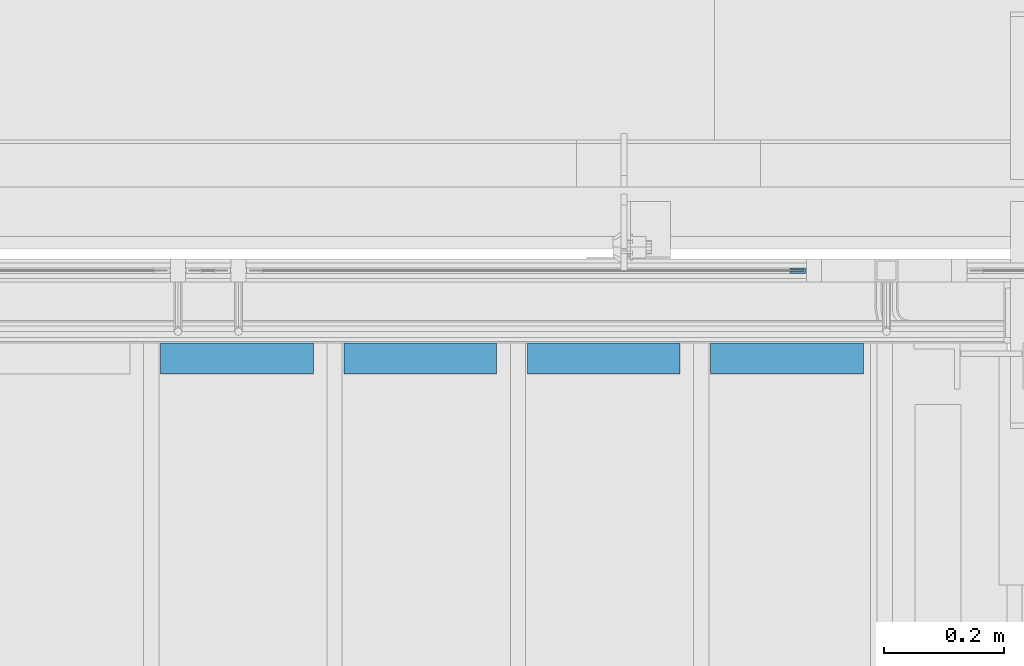
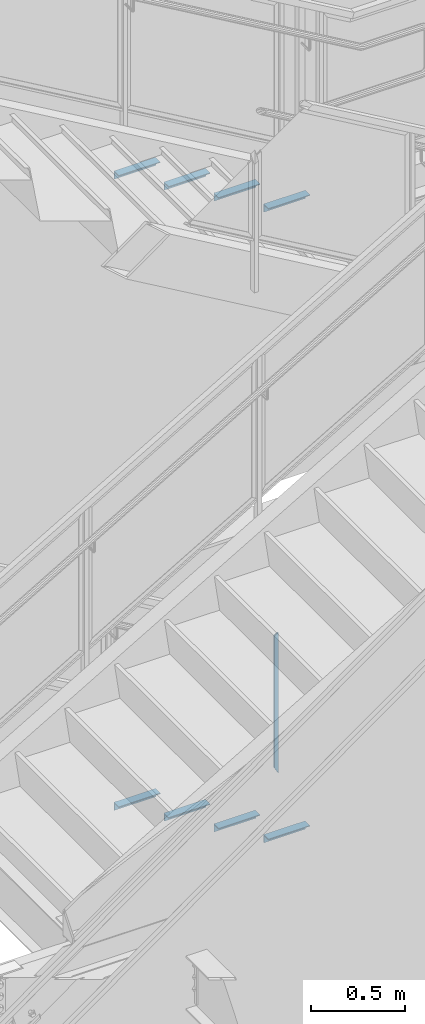
# One storey, part 946 of 1179: 9 beams, 3 elements without a shape of their own.
"""IFC2X3 building model written with IfcOpenShell, lengths in millimetres."""

from ifc_helpers import new_model, si_unit, frame, origin_with_axes, place, context, subcontext, project, spatial, faceted_brep, material, type_object, element, aggregate, save


model = new_model("IFC2X3")

# Units and contexts
model_context = context("Model", 3, precision=1e-05, world=origin_with_axes())
body_context = subcontext(model_context, "Body", "Model", "MODEL_VIEW")
ifc_project = project(units=[si_unit("LENGTHUNIT", "METRE", prefix="MILLI"), si_unit("AREAUNIT", "SQUARE_METRE"), si_unit("VOLUMEUNIT", "CUBIC_METRE"), si_unit("MASSUNIT", "GRAM", prefix="KILO"), si_unit("TIMEUNIT", "SECOND"), si_unit("PLANEANGLEUNIT", "RADIAN"), si_unit("SOLIDANGLEUNIT", "STERADIAN"), si_unit("THERMODYNAMICTEMPERATUREUNIT", "DEGREE_CELSIUS"), si_unit("LUMINOUSINTENSITYUNIT", "LUMEN")], contexts=[model_context])

# Site, building, storey
site_placement = place(None, origin_with_axes())
site = spatial("IfcSite", under=ifc_project, at=site_placement, CompositionType="ELEMENT")
building_placement = place(site_placement, origin_with_axes())
building = spatial("IfcBuilding", under=site, at=building_placement, Name="Undefined", CompositionType="ELEMENT")
storey_placement = place(building_placement, origin_with_axes())
storey = spatial("IfcBuildingStorey", under=building, at=storey_placement, Name="Undefined", CompositionType="ELEMENT", Elevation=0.0)

# Assembly, beam
assembly_1_placement = place(storey_placement, origin_with_axes())
assembly_1 = element("IfcElementAssembly", 1, at=assembly_1_placement, inside=storey, Name="GUARDRAIL", AssemblyPlace="NOTDEFINED", PredefinedType="RIGID_FRAME")
ifc_material_1 = material(Name="STEEL/BUY-OUT")
beam_type_1 = type_object("IfcBeamType", PredefinedType="NOTDEFINED")
beam_1_placement = place(assembly_1_placement, frame((22683.7873880621, 41062.2751647691, 2966.37570658179), z_axis=(0.0, 0.0, -1.0), x_axis=(1.0, 0.0, 0.0)))
beam_1 = element("IfcBeam", 2, at=beam_1_placement, type_object=beam_type_1, material=ifc_material_1, Name="U-EDGE", context=body_context, shape_type="Brep", body=[
    faceted_brep([(0.0, 1.58750000000146, 410.762302941614), (25.400000000016, 1.58750000000146, 454.819), (25.400000000016, 1.58750000000146, -454.819), (0.0, 1.58750000000146, -440.175144311391), (0.0, -1.58750000000146, 410.762302941614), (0.0, -1.58750000000146, -440.175144311391), (22.2250000000131, -1.58750000000146, 449.311912867583), (22.2250000000131, -1.58750000000146, -452.988518038564), (22.2250000000131, -4.76249999999709, 449.311912867583), (22.2250000000131, -4.76249999999709, -452.988518038564), (2.91038304567337e-11, -4.76249999999709, 410.762302941664), (2.91038304567337e-11, -4.76249999999709, -440.175144311408), (2.91038304567337e-11, -7.9375, 410.762302941664), (2.91038304567337e-11, -7.9375, -440.175144311408), (25.400000000016, -7.9375, 454.819), (25.400000000016, -7.9375, -454.819)], [[[0, 1, 2, 3]], [[4, 0, 3, 5]], [[6, 4, 5, 7]], [[8, 6, 7, 9]], [[10, 8, 9, 11]], [[12, 10, 11, 13]], [[14, 12, 13, 15]], [[11, 9, 7, 5, 3, 2, 15, 13]], [[1, 14, 15, 2]], [[0, 4, 6, 8, 10, 12, 14, 1]]]),
])
aggregate(assembly_1, [beam_1])

# Assembly, beams
assembly_2_placement = place(storey_placement, origin_with_axes())
assembly_2 = element("IfcElementAssembly", 3, at=assembly_2_placement, inside=storey, Name="STAIR", AssemblyPlace="NOTDEFINED", PredefinedType="RIGID_FRAME")
ifc_material_2 = material(Name="STEEL/A36")
beam_type_2 = type_object("IfcBeamType", Name="L2X2X3/16", PredefinedType="NOTDEFINED")
beam_2_placement = place(assembly_2_placement, frame((21637.2321734929, 40919.4000001204, 2744.8536331354), z_axis=(0.0, -1.0, 0.0), x_axis=(1.0, 0.0, 0.0)))
beam_2 = element("IfcBeam", 4, at=beam_2_placement, type_object=beam_type_2, material=ifc_material_2, Name="ANGLE", ObjectType="L2X2X3/16", context=body_context, shape_type="Brep", body=[
    faceted_brep([(0.0, 25.3999999999996, -25.4000000000015), (0.0, 25.3999999999996, 25.4000000000015), (254.0, 25.3999999999996, 25.4000000000001), (254.0, 25.3999999999996, -25.4000000000001), (0.0, 20.6374999999998, 25.4000000000015), (254.0, 20.6374999999998, 25.4000000000001), (0.0, 20.6374999999998, -20.6374999999971), (254.0, 20.6374999999998, -20.6374999999998), (0.0, -25.3999999999996, -20.6374999999971), (254.0, -25.3999999999996, -20.6374999999998), (0.0, -25.3999999999996, -25.4000000000015), (254.0, -25.3999999999996, -25.4000000000001)], [[[0, 1, 2, 3]], [[1, 4, 5, 2]], [[4, 6, 7, 5]], [[6, 8, 9, 7]], [[8, 10, 11, 9]], [[10, 0, 3, 11]], [[5, 7, 9, 11, 3, 2]], [[10, 8, 6, 4, 1, 0]]]),
])
beam_3_placement = place(assembly_2_placement, frame((21942.0321734855, 40919.4000001182, 2568.37654985169), z_axis=(0.0, -1.0, 0.0), x_axis=(1.0, 0.0, 0.0)))
beam_3 = element("IfcBeam", 5, at=beam_3_placement, type_object=beam_type_2, material=ifc_material_2, Name="ANGLE", ObjectType="L2X2X3/16", context=body_context, shape_type="Brep", body=[
    faceted_brep([(0.0, 25.3999999999996, -25.4000000000015), (0.0, 25.3999999999996, 25.4000000000015), (254.0, 25.3999999999996, 25.4000000000001), (254.0, 25.3999999999996, -25.4000000000001), (0.0, 20.6374999999998, 25.4000000000015), (254.0, 20.6374999999998, 25.4000000000001), (0.0, 20.6374999999998, -20.6374999999971), (254.0, 20.6374999999998, -20.6374999999998), (0.0, -25.3999999999996, -20.6374999999971), (254.0, -25.3999999999996, -20.6374999999998), (0.0, -25.3999999999996, -25.4000000000015), (254.0, -25.3999999999996, -25.4000000000001)], [[[0, 1, 2, 3]], [[1, 4, 5, 2]], [[4, 6, 7, 5]], [[6, 8, 9, 7]], [[8, 10, 11, 9]], [[10, 0, 3, 11]], [[5, 7, 9, 11, 3, 2]], [[10, 8, 6, 4, 1, 0]]]),
])
beam_4_placement = place(assembly_2_placement, frame((22246.8321734781, 40919.4000001159, 2391.89946656798), z_axis=(0.0, -1.0, 0.0), x_axis=(1.0, 0.0, 0.0)))
beam_4 = element("IfcBeam", 6, at=beam_4_placement, type_object=beam_type_2, material=ifc_material_2, Name="ANGLE", ObjectType="L2X2X3/16", context=body_context, shape_type="Brep", body=[
    faceted_brep([(0.0, 25.3999999999996, -25.4000000000015), (0.0, 25.3999999999996, 25.4000000000015), (254.0, 25.3999999999996, 25.4000000000001), (254.0, 25.3999999999996, -25.4000000000001), (0.0, 20.6374999999998, 25.4000000000015), (254.0, 20.6374999999998, 25.4000000000001), (0.0, 20.6374999999998, -20.6374999999971), (254.0, 20.6374999999998, -20.6374999999998), (0.0, -25.3999999999996, -20.6374999999971), (254.0, -25.3999999999996, -20.6374999999998), (0.0, -25.3999999999996, -25.4000000000015), (254.0, -25.3999999999996, -25.4000000000001)], [[[0, 1, 2, 3]], [[1, 4, 5, 2]], [[4, 6, 7, 5]], [[6, 8, 9, 7]], [[8, 10, 11, 9]], [[10, 0, 3, 11]], [[5, 7, 9, 11, 3, 2]], [[10, 8, 6, 4, 1, 0]]]),
])
beam_5_placement = place(assembly_2_placement, frame((22551.6321734706, 40919.4000001137, 2215.42238328427), z_axis=(0.0, -1.0, 0.0), x_axis=(1.0, 0.0, 0.0)))
beam_5 = element("IfcBeam", 7, at=beam_5_placement, type_object=beam_type_2, material=ifc_material_2, Name="ANGLE", ObjectType="L2X2X3/16", context=body_context, shape_type="Brep", body=[
    faceted_brep([(0.0, 25.3999999999996, -25.4000000000015), (0.0, 25.3999999999996, 25.4000000000015), (254.0, 25.3999999999996, 25.4000000000001), (254.0, 25.3999999999996, -25.4000000000001), (0.0, 20.6374999999998, 25.4000000000015), (254.0, 20.6374999999998, 25.4000000000001), (0.0, 20.6374999999998, -20.6374999999971), (254.0, 20.6374999999998, -20.6374999999998), (0.0, -25.3999999999996, -20.6374999999971), (254.0, -25.3999999999996, -20.6374999999998), (0.0, -25.3999999999996, -25.4000000000015), (254.0, -25.3999999999996, -25.4000000000001)], [[[0, 1, 2, 3]], [[1, 4, 5, 2]], [[4, 6, 7, 5]], [[6, 8, 9, 7]], [[8, 10, 11, 9]], [[10, 0, 3, 11]], [[5, 7, 9, 11, 3, 2]], [[10, 8, 6, 4, 1, 0]]]),
])
aggregate(assembly_2, [beam_2, beam_3, beam_4, beam_5])

assembly_3_placement = place(storey_placement, origin_with_axes())
assembly_3 = element("IfcElementAssembly", 8, at=assembly_3_placement, inside=storey, Name="STAIR", AssemblyPlace="NOTDEFINED", PredefinedType="RIGID_FRAME")
beam_6_placement = place(assembly_3_placement, frame((21637.2869677846, 40919.3999999982, 6823.67030000811), z_axis=(0.0, -1.0, 0.0), x_axis=(1.0, 0.0, 0.0)))
beam_6 = element("IfcBeam", 9, at=beam_6_placement, type_object=beam_type_2, material=ifc_material_2, Name="ANGLE", ObjectType="L2X2X3/16", context=body_context, shape_type="Brep", body=[
    faceted_brep([(0.0, 25.3999999999996, -25.4000000000015), (0.0, 25.3999999999996, 25.4000000000015), (254.0, 25.3999999999996, 25.4000000000001), (254.0, 25.3999999999996, -25.4000000000001), (0.0, 20.6374999999998, 25.4000000000015), (254.0, 20.6374999999998, 25.4000000000001), (0.0, 20.6374999999998, -20.6374999999971), (254.0, 20.6374999999998, -20.6374999999998), (0.0, -25.3999999999996, -20.6374999999971), (254.0, -25.3999999999996, -20.6374999999998), (0.0, -25.3999999999996, -25.4000000000015), (254.0, -25.3999999999996, -25.4000000000001)], [[[0, 1, 2, 3]], [[1, 4, 5, 2]], [[4, 6, 7, 5]], [[6, 8, 9, 7]], [[8, 10, 11, 9]], [[10, 0, 3, 11]], [[5, 7, 9, 11, 3, 2]], [[10, 8, 6, 4, 1, 0]]]),
])
beam_7_placement = place(assembly_3_placement, frame((21942.0869675326, 40919.3999999982, 6645.87030000811), z_axis=(0.0, -1.0, 0.0), x_axis=(1.0, 0.0, 0.0)))
beam_7 = element("IfcBeam", 10, at=beam_7_placement, type_object=beam_type_2, material=ifc_material_2, Name="ANGLE", ObjectType="L2X2X3/16", context=body_context, shape_type="Brep", body=[
    faceted_brep([(0.0, 25.3999999999996, -25.4000000000015), (0.0, 25.3999999999996, 25.4000000000015), (254.0, 25.3999999999996, 25.4000000000001), (254.0, 25.3999999999996, -25.4000000000001), (0.0, 20.6374999999998, 25.4000000000015), (254.0, 20.6374999999998, 25.4000000000001), (0.0, 20.6374999999998, -20.6374999999971), (254.0, 20.6374999999998, -20.6374999999998), (0.0, -25.3999999999996, -20.6374999999971), (254.0, -25.3999999999996, -20.6374999999998), (0.0, -25.3999999999996, -25.4000000000015), (254.0, -25.3999999999996, -25.4000000000001)], [[[0, 1, 2, 3]], [[1, 4, 5, 2]], [[4, 6, 7, 5]], [[6, 8, 9, 7]], [[8, 10, 11, 9]], [[10, 0, 3, 11]], [[5, 7, 9, 11, 3, 2]], [[10, 8, 6, 4, 1, 0]]]),
])
beam_8_placement = place(assembly_3_placement, frame((22246.8869672805, 40919.3999999982, 6468.07030000811), z_axis=(0.0, -1.0, 0.0), x_axis=(1.0, 0.0, 0.0)))
beam_8 = element("IfcBeam", 11, at=beam_8_placement, type_object=beam_type_2, material=ifc_material_2, Name="ANGLE", ObjectType="L2X2X3/16", context=body_context, shape_type="Brep", body=[
    faceted_brep([(0.0, 25.3999999999996, -25.4000000000015), (0.0, 25.3999999999996, 25.4000000000015), (254.0, 25.3999999999996, 25.4000000000001), (254.0, 25.3999999999996, -25.4000000000001), (0.0, 20.6374999999998, 25.4000000000015), (254.0, 20.6374999999998, 25.4000000000001), (0.0, 20.6374999999998, -20.6374999999971), (254.0, 20.6374999999998, -20.6374999999998), (0.0, -25.3999999999996, -20.6374999999971), (254.0, -25.3999999999996, -20.6374999999998), (0.0, -25.3999999999996, -25.4000000000015), (254.0, -25.3999999999996, -25.4000000000001)], [[[0, 1, 2, 3]], [[1, 4, 5, 2]], [[4, 6, 7, 5]], [[6, 8, 9, 7]], [[8, 10, 11, 9]], [[10, 0, 3, 11]], [[5, 7, 9, 11, 3, 2]], [[10, 8, 6, 4, 1, 0]]]),
])
beam_9_placement = place(assembly_3_placement, frame((22551.6869670285, 40919.3999999982, 6290.27030000811), z_axis=(0.0, -1.0, 0.0), x_axis=(1.0, 0.0, 0.0)))
beam_9 = element("IfcBeam", 12, at=beam_9_placement, type_object=beam_type_2, material=ifc_material_2, Name="ANGLE", ObjectType="L2X2X3/16", context=body_context, shape_type="Brep", body=[
    faceted_brep([(0.0, 25.3999999999996, -25.4000000000015), (0.0, 25.3999999999996, 25.4000000000015), (254.0, 25.3999999999996, 25.4000000000001), (254.0, 25.3999999999996, -25.4000000000001), (0.0, 20.6374999999998, 25.4000000000015), (254.0, 20.6374999999998, 25.4000000000001), (0.0, 20.6374999999998, -20.6374999999971), (254.0, 20.6374999999998, -20.6374999999998), (0.0, -25.3999999999996, -20.6374999999971), (254.0, -25.3999999999996, -20.6374999999998), (0.0, -25.3999999999996, -25.4000000000015), (254.0, -25.3999999999996, -25.4000000000001)], [[[0, 1, 2, 3]], [[1, 4, 5, 2]], [[4, 6, 7, 5]], [[6, 8, 9, 7]], [[8, 10, 11, 9]], [[10, 0, 3, 11]], [[5, 7, 9, 11, 3, 2]], [[10, 8, 6, 4, 1, 0]]]),
])
aggregate(assembly_3, [beam_6, beam_7, beam_8, beam_9])

save(model, "model.ifc")
